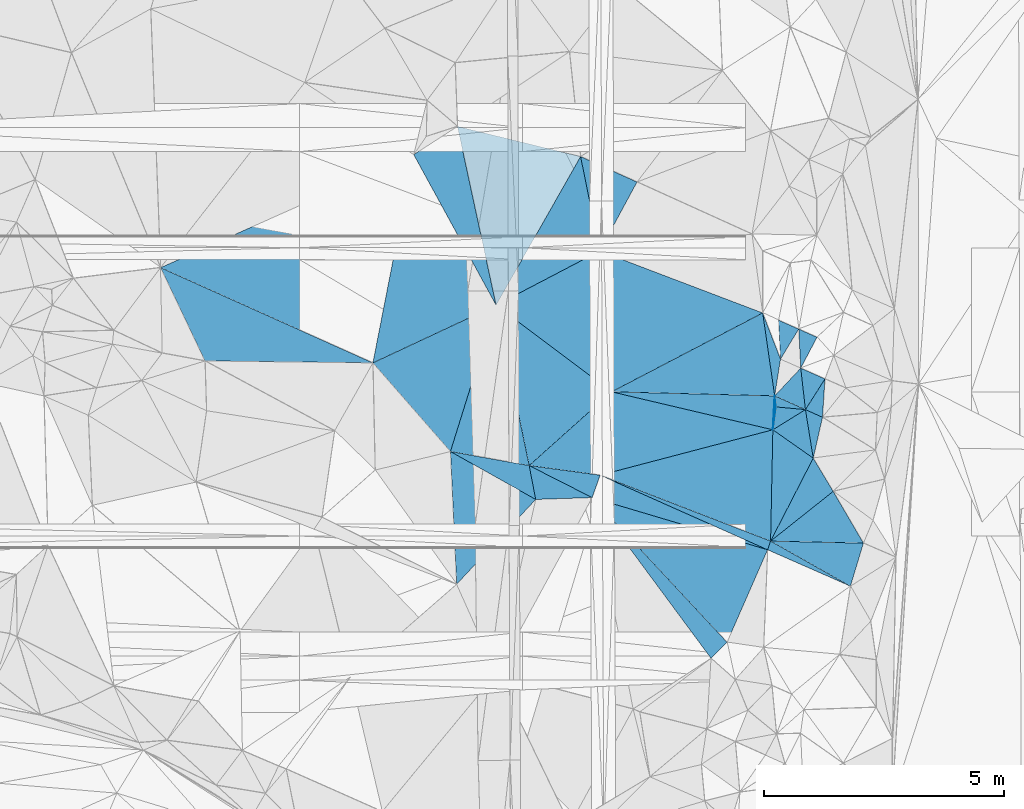
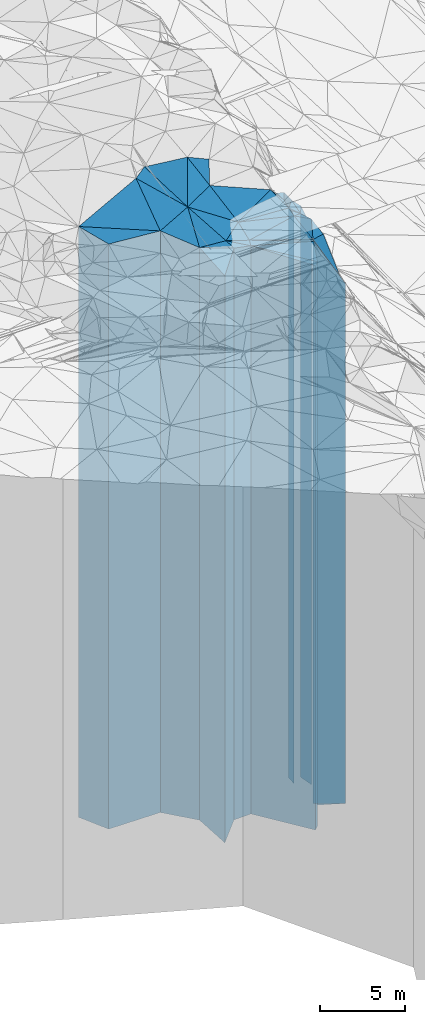
# One storey, part 212 of 275: 41 plates.
"""IFC2X3 building model written with IfcOpenShell, lengths in millimetres."""

from ifc_helpers import new_model, si_unit, frame, origin_with_axes, place, context, subcontext, project, spatial, faceted_brep, material, type_object, element, save


model = new_model("IFC2X3")

# Units and contexts
model_context = context("Model", 3, precision=1e-05, world=origin_with_axes())
body_context = subcontext(model_context, "Body", "Model", "MODEL_VIEW")
ifc_project = project(units=[si_unit("LENGTHUNIT", "METRE", prefix="MILLI"), si_unit("AREAUNIT", "SQUARE_METRE"), si_unit("VOLUMEUNIT", "CUBIC_METRE"), si_unit("MASSUNIT", "GRAM", prefix="KILO"), si_unit("TIMEUNIT", "SECOND"), si_unit("PLANEANGLEUNIT", "RADIAN"), si_unit("SOLIDANGLEUNIT", "STERADIAN"), si_unit("THERMODYNAMICTEMPERATUREUNIT", "DEGREE_CELSIUS"), si_unit("LUMINOUSINTENSITYUNIT", "LUMEN")], contexts=[model_context])

# Site, building, storey
site_placement = place(None, origin_with_axes())
site = spatial("IfcSite", under=ifc_project, at=site_placement, CompositionType="ELEMENT")
building_placement = place(site_placement, origin_with_axes())
building = spatial("IfcBuilding", under=site, at=building_placement, Name="Undefined", CompositionType="ELEMENT")
storey_placement = place(building_placement, origin_with_axes())
storey = spatial("IfcBuildingStorey", under=building, at=storey_placement, Name="Undefined", CompositionType="ELEMENT", Elevation=0.0)

# Plates
ifc_material = material()
plate_type_1 = type_object("IfcPlateType", PredefinedType="NOTDEFINED")
plate_1_placement = place(storey_placement, frame((-105195.543648921, 61054.3397016786, 28269.0), z_axis=(-0.489885939925499, -0.871786536867432, 0.0), x_axis=(-0.87178653686743, 0.489885939925502, 0.0)))
element("IfcPlate", 1, at=plate_1_placement, inside=storey, type_object=plate_type_1, material=ifc_material, Name="00", context=body_context, shape_type="Brep", body=[
    faceted_brep([(-2.91038304567337e-11, -20791.0, -8.86757334228605e-12), (569.695190429688, -20441.0, 2346.56079101562), (569.695190429688, 20441.0, 2346.56079101562), (2.91038304567337e-11, 20441.0, -1.45519152283669e-11), (2036.00097656249, -20851.0, 4.22573975811247e-09), (2036.00097656249, 20441.0, 4.22573975811247e-09)], [[[0, 1, 2, 3]], [[1, 4, 5, 2]], [[4, 0, 3, 5]], [[5, 3, 2]], [[4, 1, 0]]]),
])
plate_type_2 = type_object("IfcPlateType", PredefinedType="NOTDEFINED")
plate_2_placement = place(storey_placement, frame((-105195.543648921, 61054.3397016786, 28444.0), z_axis=(-0.981699384561619, -0.190437176914959, 0.0), x_axis=(-0.190437176914958, 0.981699384561619, 0.0)))
element("IfcPlate", 2, at=plate_2_placement, inside=storey, type_object=plate_type_2, material=ifc_material, Name="00", context=body_context, shape_type="Brep", body=[
    faceted_brep([(-1.45519152283669e-11, -20616.0, 0.0), (1317.17309570313, -20676.0, 1552.53186035156), (1317.17309570313, 20616.0, 1552.53186035156), (-1.45519152283669e-11, 20616.0, 0.0), (718.052917480469, -20776.0, 1.74622982740402e-10), (718.052917480469, 20616.0, 1.74622982740402e-10)], [[[0, 1, 2, 3]], [[1, 4, 5, 2]], [[4, 0, 3, 5]], [[5, 3, 2]], [[4, 1, 0]]]),
])
plate_type_3 = type_object("IfcPlateType", PredefinedType="NOTDEFINED")
plate_3_placement = place(storey_placement, frame((-106020.426821499, 65095.9814165758, 28474.0), z_axis=(0.423691529073487, -0.905806540157097, 0.0), x_axis=(-0.905806540157099, -0.423691529073483, 0.0)))
element("IfcPlate", 3, at=plate_3_placement, inside=storey, type_object=plate_type_3, material=ifc_material, Name="00", context=body_context, shape_type="Brep", body=[
    faceted_brep([(0.0, -21396.0, 0.0), (2150.40014648438, -20646.0, 2354.94775390625), (2150.40014648438, 20646.0, 2354.94775390625), (0.0, 20646.0, 0.0), (2830.63598632813, -21296.0, -3.18686943501234e-09), (2830.63598632813, 20646.0, -3.18686943501234e-09)], [[[0, 1, 2, 3]], [[1, 4, 5, 2]], [[4, 0, 3, 5]], [[5, 3, 2]], [[4, 1, 0]]]),
])
plate_type_4 = type_object("IfcPlateType", PredefinedType="NOTDEFINED")
plate_4_placement = place(storey_placement, frame((-106970.501894123, 62051.7479570036, 28474.0), z_axis=(0.175766110048363, 0.98443195527089, 0.0), x_axis=(0.984431955270889, -0.175766110048367, 0.0)))
element("IfcPlate", 4, at=plate_4_placement, inside=storey, type_object=plate_type_4, material=ifc_material, Name="00", context=body_context, shape_type="Brep", body=[
    faceted_brep([(1.45519152283669e-11, -20646.0, 7.27595761418343e-12), (400.21118164064, -21396.0, 3163.83178710938), (400.21118164064, 20646.0, 3163.83178710938), (0.0, 20646.0, 0.0), (1664.12133789061, -20746.0, 2.43744580075145e-09), (1664.12133789061, 20646.0, 2.43744580075145e-09)], [[[0, 1, 2, 3]], [[1, 4, 5, 2]], [[4, 0, 3, 5]], [[5, 3, 2]], [[4, 1, 0]]]),
])
plate_type_5 = type_object("IfcPlateType", PredefinedType="NOTDEFINED")
plate_5_placement = place(storey_placement, frame((-104262.03705157, 68191.4725596757, 28849.0), z_axis=(0.86950626278204, -0.493921915876193, 0.0), x_axis=(-0.49392191587619, -0.869506262782042, 0.0)))
element("IfcPlate", 5, at=plate_5_placement, inside=storey, type_object=plate_type_5, material=ifc_material, Name="00", context=body_context, shape_type="Brep", body=[
    faceted_brep([(-1.2732925824821e-11, -22121.0, 0.0), (1512.61657714842, -21131.0, 1318.5185546875), (1512.61657714842, 21021.0, 1318.5185546875), (-1.2732925824821e-11, 21021.0, 0.0), (3560.05615234374, -21021.0, 7.42147676646709e-09), (3560.05615234374, 21021.0, 7.42147676646709e-09)], [[[0, 1, 2, 3]], [[1, 4, 5, 2]], [[4, 0, 3, 5]], [[5, 3, 2]], [[4, 1, 0]]]),
])
plate_type_6 = type_object("IfcPlateType", PredefinedType="NOTDEFINED")
plate_6_placement = place(storey_placement, frame((-113003.513715425, 65878.9229417701, 28799.0), z_axis=(0.409277992984264, 0.91240973496493, 0.0), x_axis=(0.912409734964928, -0.409277992984267, 0.0)))
element("IfcPlate", 6, at=plate_6_placement, inside=storey, type_object=plate_type_6, material=ifc_material, Name="00", context=body_context, shape_type="Brep", body=[
    faceted_brep([(-1.45519152283669e-11, -21631.0, 0.0), (3845.060546875, -21841.0, 4302.1865234375), (3845.060546875, 20971.0, 4302.1865234375), (0.0, 20971.0, -1.81898940354586e-12), (4843.3046875, -20971.0, -2.0607330952771e-08), (4843.3046875, 20971.0, -2.0607330952771e-08)], [[[0, 1, 2, 3]], [[1, 4, 5, 2]], [[4, 0, 3, 5]], [[5, 3, 2]], [[4, 1, 0]]]),
])
plate_type_7 = type_object("IfcPlateType", PredefinedType="NOTDEFINED")
plate_7_placement = place(storey_placement, frame((-106020.426821499, 65095.9814165758, 28849.0), z_axis=(-0.86950626278204, 0.493921915876193, 0.0), x_axis=(0.49392191587619, 0.869506262782042, 0.0)))
element("IfcPlate", 7, at=plate_7_placement, inside=storey, type_object=plate_type_7, material=ifc_material, Name="00", context=body_context, shape_type="Brep", body=[
    faceted_brep([(0.0, -21021.0, 0.0), (2839.78662109375, -21941.0, 2537.99365234375), (2839.78662109375, 21021.0, 2537.99365234375), (-1.2732925824821e-11, 21021.0, 0.0), (3560.05615234375, -22121.0, -1.50903360918164e-08), (3560.05615234374, 21021.0, 7.42147676646709e-09)], [[[0, 1, 2, 3]], [[1, 4, 5, 2]], [[4, 0, 3, 5]], [[5, 3, 2]], [[4, 1, 0]]]),
])
plate_type_8 = type_object("IfcPlateType", PredefinedType="NOTDEFINED")
plate_8_placement = place(storey_placement, frame((-103862.691421568, 66224.9977777885, 28429.0), z_axis=(0.996489512175761, 0.0837176930147648, 0.0), x_axis=(0.0837176930147676, -0.996489512175761, 0.0)))
element("IfcPlate", 8, at=plate_8_placement, inside=storey, type_object=plate_type_8, material=ifc_material, Name="00", context=body_context, shape_type="Brep", body=[
    faceted_brep([(-1.45519152283669e-11, -21551.0, -1.45519152283669e-11), (1568.19506835936, -20841.0, 3271.0341796875), (1568.19506835936, 20601.0, 3271.0341796875), (-1.45519152283669e-11, 20601.0, -1.45519152283669e-11), (2941.08813476561, -20601.0, 2.4156179279089e-09), (2941.08813476561, 20601.0, 2.4156179279089e-09)], [[[0, 1, 2, 3]], [[1, 4, 5, 2]], [[4, 0, 3, 5]], [[5, 3, 2]], [[4, 1, 0]]]),
])
plate_type_9 = type_object("IfcPlateType", PredefinedType="NOTDEFINED")
plate_9_placement = place(storey_placement, frame((-107734.452712346, 68230.5811111951, 28799.0), z_axis=(0.981305403356164, -0.192457022069853, 0.0), x_axis=(-0.192457022069852, -0.981305403356164, 0.0)))
element("IfcPlate", 9, at=plate_9_placement, inside=storey, type_object=plate_type_9, material=ifc_material, Name="00", context=body_context, shape_type="Brep", body=[
    faceted_brep([(0.0, -21841.0, 0.0), (2746.12329101563, -21071.0, 2285.25854492188), (2746.12329101563, 20971.0, 2285.25854492188), (0.0, 20971.0, -1.81898940354586e-12), (4416.48046875001, -20971.0, -1.97178451344371e-08), (4416.48046875001, 20971.0, -1.97178451344371e-08)], [[[0, 1, 2, 3]], [[1, 4, 5, 2]], [[4, 0, 3, 5]], [[5, 3, 2]], [[4, 1, 0]]]),
])
plate_type_10 = type_object("IfcPlateType", PredefinedType="NOTDEFINED")
plate_10_placement = place(storey_placement, frame((-100101.055575703, 63973.9100933349, 28404.0), z_axis=(-0.855773744845277, 0.517350265906466, 0.0), x_axis=(0.517350265906459, 0.855773744845281, 0.0)))
element("IfcPlate", 10, at=plate_10_placement, inside=storey, type_object=plate_type_10, material=ifc_material, Name="00", context=body_context, shape_type="Brep", body=[
    faceted_brep([(0.0, -20576.0, 1.45519152283669e-11), (673.408630371079, -20606.0, 456.312194824233), (673.408630371079, 20576.0, 456.312194824233), (0.0, 20576.0, 1.45519152283669e-11), (732.393310546875, -20606.0, 1.10594555735588e-09), (732.393310546875, 20576.0, 1.10594555735588e-09)], [[[0, 1, 2, 3]], [[1, 4, 5, 2]], [[4, 0, 3, 5]], [[5, 3, 2]], [[4, 1, 0]]]),
])
plate_type_11 = type_object("IfcPlateType", PredefinedType="NOTDEFINED")
plate_11_placement = place(storey_placement, frame((-99680.0398434437, 63788.3144220748, 28134.0), z_axis=(-0.884120336204763, 0.467259276108219, 0.0), x_axis=(0.467259276108219, 0.884120336204763, 0.0)))
element("IfcPlate", 11, at=plate_11_placement, inside=storey, type_object=plate_type_11, material=ifc_material, Name="00", context=body_context, shape_type="Brep", body=[
    faceted_brep([(5.45696821063757e-12, -20796.0, 0.0), (698.545654296873, -20876.0, 416.81405639647), (698.545654296873, 20306.0, 416.81405639647), (5.45696821063757e-12, 20306.0, 0.0), (726.223083496092, -20306.0, -1.97906047105789e-09), (726.223083496092, 20306.0, -1.97906047105789e-09)], [[[0, 1, 2, 3]], [[1, 4, 5, 2]], [[4, 0, 3, 5]], [[5, 3, 2]], [[4, 1, 0]]]),
])
plate_type_12 = type_object("IfcPlateType", PredefinedType="NOTDEFINED")
plate_12_placement = place(storey_placement, frame((-100222.323223911, 63209.5841435608, 28369.0), z_axis=(-0.987646315940861, 0.156699567990614, 0.0), x_axis=(0.156699567990622, 0.98764631594086, 0.0)))
element("IfcPlate", 12, at=plate_12_placement, inside=storey, type_object=plate_type_12, material=ifc_material, Name="00", context=body_context, shape_type="Brep", body=[
    faceted_brep([(0.0, -20541.0, 0.0), (1666.13623046876, -20901.0, 517.001037597656), (1666.13623046876, 20541.0, 517.001037597656), (0.0, 20541.0, 0.0), (773.886291503906, -20611.0, -1.46974343806505e-09), (773.886291503906, 20541.0, -1.46974343806505e-09)], [[[0, 1, 2, 3]], [[1, 4, 5, 2]], [[4, 0, 3, 5]], [[5, 3, 2]], [[4, 1, 0]]]),
])
plate_type_13 = type_object("IfcPlateType", PredefinedType="NOTDEFINED")
plate_13_placement = place(storey_placement, frame((-99582.1827434494, 62924.0667793354, 28144.0), z_axis=(-0.843797889833288, 0.536661085893965, 0.0), x_axis=(0.536661085893964, 0.843797889833289, 0.0)))
element("IfcPlate", 13, at=plate_13_placement, inside=storey, type_object=plate_type_13, material=ifc_material, Name="00", context=body_context, shape_type="Brep", body=[
    faceted_brep([(-1.45519152283669e-11, -20316.0, 0.0), (676.73425292968, -20786.0, 546.379699707031), (676.73425292968, 20316.0, 546.379699707031), (0.0, 20316.0, 0.0), (757.165771484382, -20336.0, 2.5465851649642e-09), (757.165771484382, 20316.0, 2.5465851649642e-09)], [[[0, 1, 2, 3]], [[1, 4, 5, 2]], [[4, 0, 3, 5]], [[5, 3, 2]], [[4, 1, 0]]]),
])
plate_type_14 = type_object("IfcPlateType", PredefinedType="NOTDEFINED")
plate_14_placement = place(storey_placement, frame((-99175.8413399276, 63562.9616562783, 27964.0), z_axis=(0.84379788983329, -0.536661085893963, 0.0), x_axis=(-0.536661085893963, -0.84379788983329, 0.0)))
element("IfcPlate", 14, at=plate_14_placement, inside=storey, type_object=plate_type_14, material=ifc_material, Name="00", context=body_context, shape_type="Brep", body=[
    faceted_brep([(1.45519152283669e-11, -20516.0, 1.45519152283669e-11), (701.695739746095, -20136.0, 385.516632080078), (701.695739746095, 20136.0, 385.516632080078), (-6.13908923696727e-12, 20136.0, 0.0), (757.165771484376, -20496.0, 2.5465851649642e-09), (757.165771484376, 20136.0, 2.5465851649642e-09)], [[[0, 1, 2, 3]], [[1, 4, 5, 2]], [[4, 0, 3, 5]], [[5, 3, 2]], [[4, 1, 0]]]),
])
plate_type_15 = type_object("IfcPlateType", PredefinedType="NOTDEFINED")
plate_15_placement = place(storey_placement, frame((-103862.691421568, 66224.9977777885, 28904.0), z_axis=(-0.879946586467112, 0.475072631252188, 0.0), x_axis=(0.475072631252185, 0.879946586467113, 0.0)))
element("IfcPlate", 15, at=plate_15_placement, inside=storey, type_object=plate_type_15, material=ifc_material, Name="00", context=body_context, shape_type="Brep", body=[
    faceted_brep([(3.63797880709171e-12, -21076.0, 1.45519152283669e-11), (1540.67456054688, -22066.0, 1285.62121582033), (1540.67456054688, 21076.0, 1285.62121582033), (3.63797880709171e-12, 21076.0, 1.45519152283669e-11), (1632.20715332032, -21826.0, 1.54541339725256e-08), (1632.20715332032, 21076.0, 1.54541339725256e-08)], [[[0, 1, 2, 3]], [[1, 4, 5, 2]], [[4, 0, 3, 5]], [[5, 3, 2]], [[4, 1, 0]]]),
])
plate_type_16 = type_object("IfcPlateType", PredefinedType="NOTDEFINED")
plate_16_placement = place(storey_placement, frame((-100260.220410592, 62503.9894984269, 28304.0), z_axis=(-0.991399912196524, 0.130867162025945, 0.0), x_axis=(0.130867162025931, 0.991399912196526, 0.0)))
element("IfcPlate", 16, at=plate_16_placement, inside=storey, type_object=plate_type_16, material=ifc_material, Name="00", context=body_context, shape_type="Brep", body=[
    faceted_brep([(0.0, -20476.0, -1.45519152283669e-11), (704.485961914055, -20606.0, 54.7679023742676), (704.485961914055, 20476.0, 54.7679023742676), (0.0, 20476.0, 0.0), (480.208282470703, -20566.0, 4.65661287307739e-10), (480.208282470703, 20476.0, 4.65661287307739e-10)], [[[0, 1, 2, 3]], [[1, 4, 5, 2]], [[4, 0, 3, 5]], [[5, 3, 2]], [[4, 1, 0]]]),
])
plate_type_17 = type_object("IfcPlateType", PredefinedType="NOTDEFINED")
plate_17_placement = place(storey_placement, frame((-100471.854542837, 64936.1512928125, 28369.0), z_axis=(0.462842511862217, -0.88644052773611, 0.0), x_axis=(-0.886440527736111, -0.462842511862215, 0.0)))
element("IfcPlate", 17, at=plate_17_placement, inside=storey, type_object=plate_type_17, material=ifc_material, Name="00", context=body_context, shape_type="Brep", body=[
    faceted_brep([(-1.45519152283669e-11, -20901.0, -1.45519152283669e-11), (577.934020996086, -20541.0, 1645.99279785158), (577.934020996086, 20541.0, 1645.99279785158), (0.0, 20541.0, 0.0), (3547.46386718749, -20661.0, -3.92901711165905e-10), (3547.46386718749, 20541.0, -3.92901711165905e-10)], [[[0, 1, 2, 3]], [[1, 4, 5, 2]], [[4, 0, 3, 5]], [[5, 3, 2]], [[4, 1, 0]]]),
])
plate_type_18 = type_object("IfcPlateType", PredefinedType="NOTDEFINED")
plate_18_placement = place(storey_placement, frame((-99419.6222398632, 61913.4857174339, 27964.0), z_axis=(-0.975327778178171, 0.220761693040327, 0.0), x_axis=(0.220761693040322, 0.975327778178173, 0.0)))
element("IfcPlate", 18, at=plate_18_placement, inside=storey, type_object=plate_type_18, material=ifc_material, Name="00", context=body_context, shape_type="Brep", body=[
    faceted_brep([(0.0, -20656.0, 1.45519152283669e-11), (949.760620117195, -20496.0, 381.64736938478), (949.760620117195, 20136.0, 381.64736938478), (-6.13908923696727e-12, 20136.0, 0.0), (872.009155273445, -20136.0, -7.56699591875076e-10), (872.009155273445, 20136.0, -7.56699591875076e-10)], [[[0, 1, 2, 3]], [[1, 4, 5, 2]], [[4, 0, 3, 5]], [[5, 3, 2]], [[4, 1, 0]]]),
])
plate_type_19 = type_object("IfcPlateType", PredefinedType="NOTDEFINED")
plate_19_placement = place(storey_placement, frame((-99680.0398434437, 63788.3144220748, 28144.0), z_axis=(0.729710981343988, -0.683755719322328, 0.0), x_axis=(-0.683755719322331, -0.729710981343986, 0.0)))
element("IfcPlate", 19, at=plate_19_placement, inside=storey, type_object=plate_type_19, material=ifc_material, Name="00", context=body_context, shape_type="Brep", body=[
    faceted_brep([(-5.45696821063757e-12, -20786.0, 0.0), (563.740661621101, -20316.0, 662.341674804644), (563.740661621101, 20316.0, 662.341674804644), (0.0, 20316.0, 0.0), (793.095214843757, -20766.0, -3.78349795937538e-10), (793.095214843757, 20316.0, -3.78349795937538e-10)], [[[0, 1, 2, 3]], [[1, 4, 5, 2]], [[4, 0, 3, 5]], [[5, 3, 2]], [[4, 1, 0]]]),
])
plate_type_20 = type_object("IfcPlateType", PredefinedType="NOTDEFINED")
plate_20_placement = place(storey_placement, frame((-103862.691421568, 66224.9977777885, 28429.0), z_axis=(0.463611906096083, -0.886038374183623, 0.0), x_axis=(-0.886038374183624, -0.463611906096081, 0.0)))
element("IfcPlate", 20, at=plate_20_placement, inside=storey, type_object=plate_type_20, material=ifc_material, Name="00", context=body_context, shape_type="Brep", body=[
    faceted_brep([(-1.45519152283669e-11, -21551.0, -1.45519152283669e-11), (1140.57556152344, -20601.0, 2710.91992187499), (1140.57556152344, 20601.0, 2710.91992187499), (-1.45519152283669e-11, 20601.0, -1.45519152283669e-11), (2435.26171875, -21441.0, -4.77302819490433e-09), (2435.26171875, 20601.0, -4.77302819490433e-09)], [[[0, 1, 2, 3]], [[1, 4, 5, 2]], [[4, 0, 3, 5]], [[5, 3, 2]], [[4, 1, 0]]]),
])
plate_type_21 = type_object("IfcPlateType", PredefinedType="NOTDEFINED")
plate_21_placement = place(storey_placement, frame((-105332.287620473, 61759.251814104, 28344.0), z_axis=(0.134052468942307, 0.990974235573495, 0.0), x_axis=(0.990974235573495, -0.134052468942304, 0.0)))
element("IfcPlate", 21, at=plate_21_placement, inside=storey, type_object=plate_type_21, material=ifc_material, Name="00", context=body_context, shape_type="Brep", body=[
    faceted_brep([(1.45519152283669e-11, -20876.0, 0.0), (1494.56262207031, -20686.0, 1751.13757324219), (1494.56262207031, 20516.0, 1751.13757324219), (1.45519152283669e-11, 20516.0, 0.0), (1490.40258789063, -20516.0, -2.71393219009042e-09), (1490.40258789063, 20516.0, -2.71393219009042e-09)], [[[0, 1, 2, 3]], [[1, 4, 5, 2]], [[4, 0, 3, 5]], [[5, 3, 2]], [[4, 1, 0]]]),
])
plate_type_22 = type_object("IfcPlateType", PredefinedType="NOTDEFINED")
plate_22_placement = place(storey_placement, frame((-107734.452712346, 68230.5811111951, 28849.0), z_axis=(0.877395685046794, 0.479767456025591, 0.0), x_axis=(0.479767456025587, -0.877395685046796, 0.0)))
element("IfcPlate", 22, at=plate_22_placement, inside=storey, type_object=plate_type_22, material=ifc_material, Name="00", context=body_context, shape_type="Brep", body=[
    faceted_brep([(7.27595761418343e-12, -21791.0, 1.45519152283669e-11), (-79.5495071411133, -21941.0, 1080.49609375001), (-79.5495071411133, 21021.0, 1080.49609375001), (-1.2732925824821e-11, 21021.0, 0.0), (3572.6181640625, -21021.0, 1.17142917588353e-08), (3572.6181640625, 21021.0, 1.17142917588353e-08)], [[[0, 1, 2, 3]], [[1, 4, 5, 2]], [[4, 0, 3, 5]], [[5, 3, 2]], [[4, 1, 0]]]),
])
plate_type_23 = type_object("IfcPlateType", PredefinedType="NOTDEFINED")
plate_23_placement = place(storey_placement, frame((-100307.280430817, 60187.0550249261, 28169.0), z_axis=(-0.889333984307665, 0.457258203158187, 0.0), x_axis=(0.457258203158189, 0.889333984307664, 0.0)))
element("IfcPlate", 23, at=plate_23_placement, inside=storey, type_object=plate_type_23, material=ifc_material, Name="00", context=body_context, shape_type="Brep", body=[
    faceted_brep([(7.27595761418343e-12, -20341.0, 1.45519152283669e-11), (2082.04711914064, -20611.0, 1017.58520507814), (2082.04711914064, 20341.0, 1017.58520507814), (7.27595761418343e-12, 20341.0, 1.45519152283669e-11), (1941.26245117188, -20451.0, -5.20958565175533e-09), (1941.26245117188, 20341.0, -5.20958565175533e-09)], [[[0, 1, 2, 3]], [[1, 4, 5, 2]], [[4, 0, 3, 5]], [[5, 3, 2]], [[4, 1, 0]]]),
])
plate_type_24 = type_object("IfcPlateType", PredefinedType="NOTDEFINED")
plate_24_placement = place(storey_placement, frame((-99582.1827434494, 62924.0667793354, 28144.0), z_axis=(-0.0906552470465347, -0.995882335511044, 0.0), x_axis=(-0.995882335511045, 0.0906552470465209, 0.0)))
element("IfcPlate", 24, at=plate_24_placement, inside=storey, type_object=plate_type_24, material=ifc_material, Name="00", context=body_context, shape_type="Brep", body=[
    faceted_brep([(-1.45519152283669e-11, -20316.0, 0.0), (637.163513183594, -20636.0, 479.815216064439), (637.163513183594, 20316.0, 479.815216064439), (0.0, 20316.0, 0.0), (617.737792968765, -20726.0, 1.29512045532465e-09), (617.737792968765, 20316.0, 1.29512045532465e-09)], [[[0, 1, 2, 3]], [[1, 4, 5, 2]], [[4, 0, 3, 5]], [[5, 3, 2]], [[4, 1, 0]]]),
])
plate_type_25 = type_object("IfcPlateType", PredefinedType="NOTDEFINED")
plate_25_placement = place(storey_placement, frame((-100307.280430817, 60187.0550249261, 27814.0), z_axis=(-0.622161813924402, 0.782888674904866, 0.0), x_axis=(0.782888674904872, 0.622161813924396, 0.0)))
element("IfcPlate", 25, at=plate_25_placement, inside=storey, type_object=plate_type_25, material=ifc_material, Name="00", context=body_context, shape_type="Brep", body=[
    faceted_brep([(0.0, -20696.0, 0.0), (1769.05676269531, -20806.0, 799.335998535171), (1769.05676269531, 19986.0, 799.335998535171), (-7.27595761418343e-12, 19986.0, 1.45519152283669e-11), (1663.88098144531, -19986.0, -5.0931703299284e-10), (1663.88098144531, 19986.0, -5.0931703299284e-10)], [[[0, 1, 2, 3]], [[1, 4, 5, 2]], [[4, 0, 3, 5]], [[5, 3, 2]], [[4, 1, 0]]]),
])
plate_type_26 = type_object("IfcPlateType", PredefinedType="NOTDEFINED")
plate_26_placement = place(storey_placement, frame((-99582.1827434494, 62924.0667793354, 28144.0), z_axis=(0.5266624579429, -0.850074499907828, 0.0), x_axis=(-0.85007449990783, -0.526662457942895, 0.0)))
element("IfcPlate", 26, at=plate_26_placement, inside=storey, type_object=plate_type_26, material=ifc_material, Name="00", context=body_context, shape_type="Brep", body=[
    faceted_brep([(-1.45519152283669e-11, -20316.0, 0.0), (394.046569824226, -20476.0, 944.683715820313), (394.046569824226, 20316.0, 944.683715820313), (0.0, 20316.0, 0.0), (797.621459960938, -20636.0, -3.20142135024071e-09), (797.621459960938, 20316.0, -3.20142135024071e-09)], [[[0, 1, 2, 3]], [[1, 4, 5, 2]], [[4, 0, 3, 5]], [[5, 3, 2]], [[4, 1, 0]]]),
])
plate_type_27 = type_object("IfcPlateType", PredefinedType="NOTDEFINED")
plate_27_placement = place(storey_placement, frame((-103616.470299132, 63294.2341982983, 28429.0), z_axis=(-0.599740029767575, -0.800194911689888, 0.0), x_axis=(-0.800194911689889, 0.599740029767575, 0.0)))
element("IfcPlate", 27, at=plate_27_placement, inside=storey, type_object=plate_type_27, material=ifc_material, Name="00", context=body_context, shape_type="Brep", body=[
    faceted_brep([(1.45519152283669e-11, -20601.0, 3.63797880709171e-12), (452.397918701186, -20791.0, 2257.32934570314), (452.397918701186, 20601.0, 2257.32934570314), (-1.45519152283669e-11, 20601.0, -1.45519152283669e-11), (3004.21362304689, -21441.0, 3.45607986673713e-10), (3004.21362304689, 20601.0, 3.45607986673713e-10)], [[[0, 1, 2, 3]], [[1, 4, 5, 2]], [[4, 0, 3, 5]], [[5, 3, 2]], [[4, 1, 0]]]),
])
plate_type_28 = type_object("IfcPlateType", PredefinedType="NOTDEFINED")
plate_28_placement = place(storey_placement, frame((-99004.6468349279, 61222.258248869, 26369.0), z_axis=(0.622161813924402, -0.782888674904866, 0.0), x_axis=(-0.782888674904867, -0.622161813924401, 0.0)))
element("IfcPlate", 28, at=plate_28_placement, inside=storey, type_object=plate_type_28, material=ifc_material, Name="00", context=body_context, shape_type="Brep", body=[
    faceted_brep([(0.0, -21431.0, 0.0), (177.536727905273, -18541.0, 1235.18444824219), (177.536727905273, 18541.0, 1235.18444824219), (-7.27595761418343e-12, 18541.0, 0.0), (1663.8809814453, -22141.0, -5.5297277867794e-10), (1663.8809814453, 18541.0, -5.5297277867794e-10)], [[[0, 1, 2, 3]], [[1, 4, 5, 2]], [[4, 0, 3, 5]], [[5, 3, 2]], [[4, 1, 0]]]),
])
plate_type_29 = type_object("IfcPlateType", PredefinedType="NOTDEFINED")
plate_29_placement = place(storey_placement, frame((-105332.287620473, 61759.251814104, 28314.0), z_axis=(0.453049356842504, 0.891485434690098, 0.0), x_axis=(0.891485434690096, -0.453049356842509, 0.0)))
element("IfcPlate", 29, at=plate_29_placement, inside=storey, type_object=plate_type_29, material=ifc_material, Name="00", context=body_context, shape_type="Brep", body=[
    faceted_brep([(0.0, -20906.0, 2.91038304567337e-11), (1407.19567871091, -20546.0, 491.019714355464), (1407.19567871091, 20486.0, 491.019714355464), (-2.91038304567337e-11, 20486.0, 2.72848410531878e-12), (1471.22399902341, -20486.0, -1.028547558235e-08), (1471.22399902341, 20486.0, -1.028547558235e-08)], [[[0, 1, 2, 3]], [[1, 4, 5, 2]], [[4, 0, 3, 5]], [[5, 3, 2]], [[4, 1, 0]]]),
])
plate_type_30 = type_object("IfcPlateType", PredefinedType="NOTDEFINED")
plate_30_placement = place(storey_placement, frame((-100222.323223911, 63209.5841435608, 28144.0), z_axis=(0.994144976290378, 0.108054459031561, 0.0), x_axis=(0.108054459031538, -0.994144976290381, 0.0)))
element("IfcPlate", 30, at=plate_30_placement, inside=storey, type_object=plate_type_30, material=ifc_material, Name="00", context=body_context, shape_type="Brep", body=[
    faceted_brep([(-1.45519152283669e-11, -20766.0, -1.45519152283669e-11), (353.015686035156, -20316.0, 605.541015624985), (353.015686035156, 20316.0, 605.541015624985), (0.0, 20316.0, 0.0), (230.86793518065, -20726.0, -2.3283064365387e-10), (230.86793518065, 20316.0, -2.3283064365387e-10)], [[[0, 1, 2, 3]], [[1, 4, 5, 2]], [[4, 0, 3, 5]], [[5, 3, 2]], [[4, 1, 0]]]),
])
plate_type_31 = type_object("IfcPlateType", PredefinedType="NOTDEFINED")
plate_31_placement = place(storey_placement, frame((-100307.280430817, 60187.0550249261, 28164.0), z_axis=(-0.360757109901238, -0.932659802744659, 0.0), x_axis=(-0.932659802744667, 0.360757109901216, 0.0)))
element("IfcPlate", 31, at=plate_31_placement, inside=storey, type_object=plate_type_31, material=ifc_material, Name="00", context=body_context, shape_type="Brep", body=[
    faceted_brep([(5.45696821063757e-12, -20346.0, 0.0), (-7.07106781004404, -20336.0, 190.918838500987), (-7.07106781004404, 20336.0, 190.918838500987), (1.45519152283669e-11, 20336.0, 3.63797880709171e-12), (3804.23437500001, -20696.0, 1.51230779010803e-08), (3804.23437500001, 20336.0, 1.51230779010803e-08)], [[[0, 1, 2, 3]], [[1, 4, 5, 2]], [[4, 0, 3, 5]], [[5, 3, 2]], [[4, 1, 0]]]),
])
plate_type_32 = type_object("IfcPlateType", PredefinedType="NOTDEFINED")
plate_32_placement = place(storey_placement, frame((-100260.220410592, 62503.9894984269, 28304.0), z_axis=(-0.229187409045969, -0.973382315195214, 0.0), x_axis=(-0.973382315195216, 0.229187409045964, 0.0)))
element("IfcPlate", 32, at=plate_32_placement, inside=storey, type_object=plate_type_32, material=ifc_material, Name="00", context=body_context, shape_type="Brep", body=[
    faceted_brep([(0.0, -20476.0, -1.45519152283669e-11), (3282.94848632813, -20556.0, 1743.34411621094), (3282.94848632813, 20476.0, 1743.34411621094), (0.0, 20476.0, 0.0), (3448.02832031251, -20726.0, 1.42099452205002e-08), (3448.02832031251, 20476.0, 1.42099452205002e-08)], [[[0, 1, 2, 3]], [[1, 4, 5, 2]], [[4, 0, 3, 5]], [[5, 3, 2]], [[4, 1, 0]]]),
])
plate_type_33 = type_object("IfcPlateType", PredefinedType="NOTDEFINED")
plate_33_placement = place(storey_placement, frame((-98375.1537153246, 60144.7897285065, 26369.0), z_axis=(-0.0218697809942688, -0.999760827737946, 0.0), x_axis=(-0.999760827737946, 0.0218697809942684, 0.0)))
element("IfcPlate", 33, at=plate_33_placement, inside=storey, type_object=plate_type_33, material=ifc_material, Name="00", context=body_context, shape_type="Brep", body=[
    faceted_brep([(0.0, -18541.0, 0.0), (251.113922119155, -18951.0, 901.743774414063), (251.113922119155, 18541.0, 901.743774414063), (-7.27595761418343e-12, 18541.0, 0.0), (1932.58898925783, -22141.0, 1.28056854009628e-09), (1932.58898925783, 18541.0, 1.28056854009628e-09)], [[[0, 1, 2, 3]], [[1, 4, 5, 2]], [[4, 0, 3, 5]], [[5, 3, 2]], [[4, 1, 0]]]),
])
plate_type_34 = type_object("IfcPlateType", PredefinedType="NOTDEFINED")
plate_34_placement = place(storey_placement, frame((-100307.280430817, 60187.0550249261, 26574.0), z_axis=(0.945372995473243, -0.325990643163185, 0.0), x_axis=(-0.325990643163193, -0.945372995473241, 0.0)))
element("IfcPlate", 34, at=plate_34_placement, inside=storey, type_object=plate_type_34, material=ifc_material, Name="00", context=body_context, shape_type="Brep", body=[
    faceted_brep([(-7.27595761418343e-12, -21936.0, -2.91038304567337e-11), (345.459777832046, -18746.0, 1876.47473144531), (345.459777832046, 18746.0, 1876.47473144531), (3.63797880709171e-12, 18746.0, -1.45519152283669e-11), (191.049728393566, -21926.0, 1.30967237055302e-10), (191.049728393566, 18746.0, 1.30967237055302e-10)], [[[0, 1, 2, 3]], [[1, 4, 5, 2]], [[4, 0, 3, 5]], [[5, 3, 2]], [[4, 1, 0]]]),
])
plate_type_35 = type_object("IfcPlateType", PredefinedType="NOTDEFINED")
plate_35_placement = place(storey_placement, frame((-105195.543648921, 61054.3397016786, 28314.0), z_axis=(-0.0326468960006117, 0.999466948018555, 0.0), x_axis=(0.999466948018555, 0.0326468960006061, 0.0)))
element("IfcPlate", 35, at=plate_35_placement, inside=storey, type_object=plate_type_35, material=ifc_material, Name="00", context=body_context, shape_type="Brep", body=[
    faceted_brep([(-2.91038304567337e-11, -20746.0, 1.45519152283669e-11), (-113.657890319839, -20906.0, 709.000610351577), (-113.657890319839, 20486.0, 709.000610351577), (-2.91038304567337e-11, 20486.0, 2.72848410531878e-12), (1175.45739746092, -20486.0, 2.16095941141248e-09), (1175.45739746092, 20486.0, 2.16095941141248e-09)], [[[0, 1, 2, 3]], [[1, 4, 5, 2]], [[4, 0, 3, 5]], [[5, 3, 2]], [[4, 1, 0]]]),
])
plate_type_36 = type_object("IfcPlateType", PredefinedType="NOTDEFINED")
plate_36_placement = place(storey_placement, frame((-100222.323223911, 63209.5841435608, 28304.0), z_axis=(-0.0249322550003627, -0.999689143014266, 0.0), x_axis=(-0.999689143014266, 0.0249322550003567, 0.0)))
element("IfcPlate", 36, at=plate_36_placement, inside=storey, type_object=plate_type_36, material=ifc_material, Name="00", context=body_context, shape_type="Brep", body=[
    faceted_brep([(0.0, -20606.0, -7.27595761418343e-12), (20.2933406829834, -20476.0, 706.32019042968), (20.2933406829834, 20476.0, 706.32019042968), (0.0, 20476.0, 0.0), (3395.20239257813, -20726.0, 8.72387317940593e-09), (3395.20239257813, 20476.0, 8.72387317940593e-09)], [[[0, 1, 2, 3]], [[1, 4, 5, 2]], [[4, 0, 3, 5]], [[5, 3, 2]], [[4, 1, 0]]]),
])
plate_type_37 = type_object("IfcPlateType", PredefinedType="NOTDEFINED")
plate_37_placement = place(storey_placement, frame((-101546.592683376, 57747.5048326457, 28159.0), z_axis=(-0.706835456151179, 0.707378002151293, 0.0), x_axis=(0.707378002151304, 0.706835456151168, 0.0)))
element("IfcPlate", 37, at=plate_37_placement, inside=storey, type_object=plate_type_37, material=ifc_material, Name="00", context=body_context, shape_type="Brep", body=[
    faceted_brep([(-1.09139364212751e-11, -20351.0, 0.0), (614.374755859444, -20641.0, 4115.12353515624), (614.374755859444, 20331.0, 4115.12353515624), (-1.09139364212751e-11, 20331.0, 0.0), (471.699066162098, -20331.0, 1.46974343806505e-09), (471.699066162098, 20331.0, 1.46974343806505e-09)], [[[0, 1, 2, 3]], [[1, 4, 5, 2]], [[4, 0, 3, 5]], [[5, 3, 2]], [[4, 1, 0]]]),
])
plate_type_38 = type_object("IfcPlateType", PredefinedType="NOTDEFINED")
plate_38_placement = place(storey_placement, frame((-100369.560855743, 60006.441767741, 28164.0), z_axis=(-0.406966340140535, -0.913443155315435, 0.0), x_axis=(-0.913443155315435, 0.406966340140535, 0.0)))
element("IfcPlate", 38, at=plate_38_placement, inside=storey, type_object=plate_type_38, material=ifc_material, Name="00", context=body_context, shape_type="Brep", body=[
    faceted_brep([(0.0, -20336.0, -7.27595761418343e-12), (3777.1962890625, -20636.0, 493.647369384773), (3777.1962890625, 20336.0, 493.647369384773), (1.45519152283669e-11, 20336.0, 3.63797880709171e-12), (3816.08447265625, -20696.0, 9.82254277914763e-10), (3816.08447265625, 20336.0, 9.82254277914763e-10)], [[[0, 1, 2, 3]], [[1, 4, 5, 2]], [[4, 0, 3, 5]], [[5, 3, 2]], [[4, 1, 0]]]),
])
plate_type_39 = type_object("IfcPlateType", PredefinedType="NOTDEFINED")
plate_39_placement = place(storey_placement, frame((-104020.712871003, 61092.7147359524, 28159.0), z_axis=(0.731445241906351, 0.68190018191269, 0.0), x_axis=(0.681900181912692, -0.731445241906349, 0.0)))
element("IfcPlate", 39, at=plate_39_placement, inside=storey, type_object=plate_type_39, material=ifc_material, Name="00", context=body_context, shape_type="Brep", body=[
    faceted_brep([(1.45519152283669e-11, -20641.0, -7.27595761418343e-12), (3284.27050781249, -20341.0, 1929.88806152344), (3284.27050781249, 20331.0, 1929.88806152344), (-1.09139364212751e-11, 20331.0, 0.0), (4117.59619140625, -20331.0, 1.92085281014442e-09), (4117.59619140625, 20331.0, 1.92085281014442e-09)], [[[0, 1, 2, 3]], [[1, 4, 5, 2]], [[4, 0, 3, 5]], [[5, 3, 2]], [[4, 1, 0]]]),
])
plate_type_40 = type_object("IfcPlateType", PredefinedType="NOTDEFINED")
plate_40_placement = place(storey_placement, frame((-100260.220410592, 62503.9894984269, 28169.0), z_axis=(0.25410242088019, -0.967177315543963, 0.0), x_axis=(-0.967177315543964, -0.254102420880188, 0.0)))
element("IfcPlate", 40, at=plate_40_placement, inside=storey, type_object=plate_type_40, material=ifc_material, Name="00", context=body_context, shape_type="Brep", body=[
    faceted_brep([(0.0, -20611.0, 0.0), (634.254028320313, -20341.0, 2228.92846679688), (634.254028320313, 20341.0, 2228.92846679688), (7.27595761418343e-12, 20341.0, 1.45519152283669e-11), (3717.12255859375, -20691.0, 7.7707227319479e-09), (3717.12255859375, 20341.0, 7.7707227319479e-09)], [[[0, 1, 2, 3]], [[1, 4, 5, 2]], [[4, 0, 3, 5]], [[5, 3, 2]], [[4, 1, 0]]]),
])
plate_type_41 = type_object("IfcPlateType", PredefinedType="NOTDEFINED")
plate_41_placement = place(storey_placement, frame((-112079.186697475, 63936.8313981279, 28799.0), z_axis=(0.0114926099974374, 0.999933957776936, 0.0), x_axis=(0.999933957776936, -0.0114926099974361, 0.0)))
element("IfcPlate", 41, at=plate_41_placement, inside=storey, type_object=plate_type_41, material=ifc_material, Name="00", context=body_context, shape_type="Brep", body=[
    faceted_brep([(1.09139364212751e-11, -21221.0, 0.0), (-946.58569335939, -21631.0, 1931.34033203126), (-946.58569335939, 20971.0, 1931.34033203126), (0.0, 20971.0, -1.81898940354586e-12), (3494.98217773436, -20971.0, 7.79255060479045e-09), (3494.98217773436, 20971.0, 7.79255060479045e-09)], [[[0, 1, 2, 3]], [[1, 4, 5, 2]], [[4, 0, 3, 5]], [[5, 3, 2]], [[4, 1, 0]]]),
])

save(model, "model.ifc")
